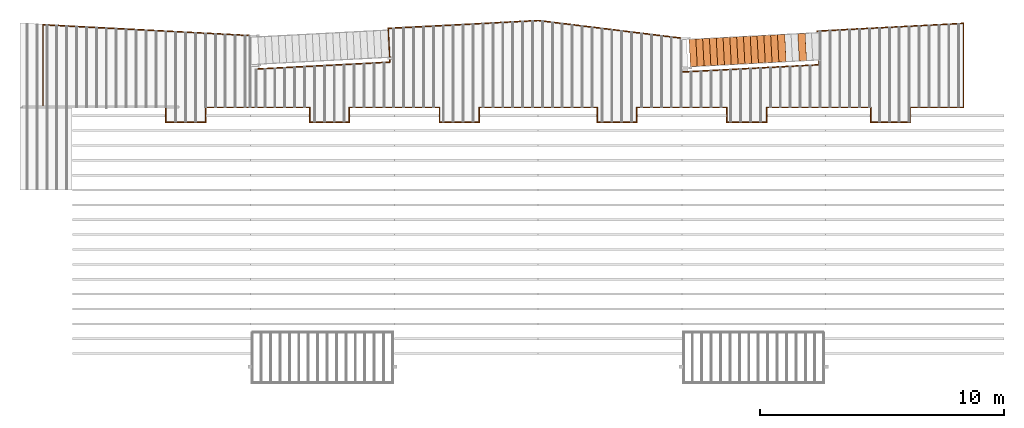
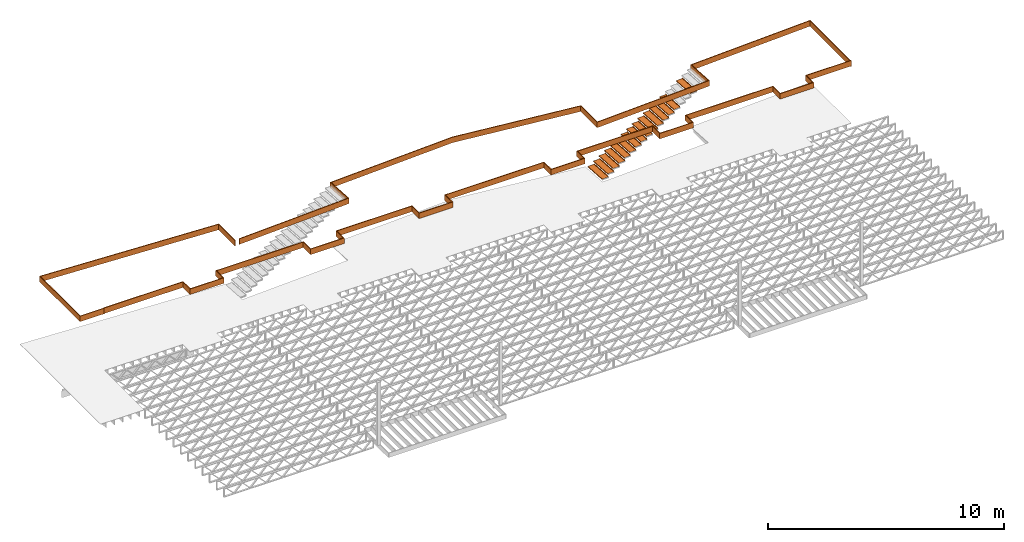
# One storey, part 15 of 23: 17 proxies.
"""IFC4 building model written with IfcOpenShell, lengths in feet."""

from ifc_helpers import new_model, entity, si_unit, converted_unit, derived_unit, direction, frame, origin, place, context, subcontext, project, spatial, polyline, outline, extrude, source, transform, mapped, material, type_object, type_shapes, element, save


model = new_model("IFC4")

# Units and contexts
model_context_1 = context("Model", 3, precision=0.0001, world=origin(), true_north=direction((6.12303176911189e-17, 1.0)))
model_context_2 = context("Model", 3, precision=0.0001, world=origin(), true_north=direction((6.12303176911189e-17, 1.0)))
body_context = subcontext(model_context_2, "Body", "Model", "MODEL_VIEW")
ifc_project = project(units=[converted_unit("LENGTHUNIT", "FOOT", entity("IfcRatioMeasure", 0.3048), si_unit("LENGTHUNIT", "METRE"), dimensions=[1, 0, 0, 0, 0, 0, 0]), converted_unit("AREAUNIT", "SQUARE FOOT", entity("IfcRatioMeasure", 0.09290304), si_unit("AREAUNIT", "SQUARE_METRE"), dimensions=[2, 0, 0, 0, 0, 0, 0]), converted_unit("VOLUMEUNIT", "CUBIC FOOT", entity("IfcRatioMeasure", 0.028316846592), si_unit("VOLUMEUNIT", "CUBIC_METRE"), dimensions=[3, 0, 0, 0, 0, 0, 0]), converted_unit("PLANEANGLEUNIT", "DEGREE", entity("IfcRatioMeasure", 0.0174532925199433), si_unit("PLANEANGLEUNIT", "RADIAN"), dimensions=[0, 0, 0, 0, 0, 0, 0]), si_unit("MASSUNIT", "GRAM", prefix="KILO"), derived_unit("MASSDENSITYUNIT", [(si_unit("MASSUNIT", "GRAM", prefix="KILO"), 1), (si_unit("LENGTHUNIT", "METRE"), -3)]), derived_unit("MOMENTOFINERTIAUNIT", [(si_unit("LENGTHUNIT", "METRE"), 4)]), si_unit("TIMEUNIT", "SECOND"), si_unit("FREQUENCYUNIT", "HERTZ"), si_unit("THERMODYNAMICTEMPERATUREUNIT", "DEGREE_CELSIUS"), derived_unit("THERMALTRANSMITTANCEUNIT", [(si_unit("MASSUNIT", "GRAM", prefix="KILO"), 1), (si_unit("THERMODYNAMICTEMPERATUREUNIT", "KELVIN"), -1), (si_unit("TIMEUNIT", "SECOND"), -3)]), derived_unit("VOLUMETRICFLOWRATEUNIT", [(si_unit("LENGTHUNIT", "METRE"), 3), (si_unit("TIMEUNIT", "SECOND"), -1)]), si_unit("ELECTRICCURRENTUNIT", "AMPERE"), si_unit("ELECTRICVOLTAGEUNIT", "VOLT"), si_unit("POWERUNIT", "WATT"), si_unit("FORCEUNIT", "NEWTON"), si_unit("ILLUMINANCEUNIT", "LUX"), si_unit("LUMINOUSFLUXUNIT", "LUMEN"), si_unit("LUMINOUSINTENSITYUNIT", "CANDELA"), derived_unit("USERDEFINED", [(si_unit("MASSUNIT", "GRAM", prefix="KILO"), -1), (si_unit("LENGTHUNIT", "METRE"), -2), (si_unit("TIMEUNIT", "SECOND"), 3), (si_unit("LUMINOUSFLUXUNIT", "LUMEN"), 1)]), derived_unit("LINEARVELOCITYUNIT", [(si_unit("LENGTHUNIT", "METRE"), 1), (si_unit("TIMEUNIT", "SECOND"), -1)]), si_unit("PRESSUREUNIT", "PASCAL"), derived_unit("USERDEFINED", [(si_unit("LENGTHUNIT", "METRE"), -2), (si_unit("MASSUNIT", "GRAM", prefix="KILO"), 1), (si_unit("TIMEUNIT", "SECOND"), -2)]), derived_unit("LINEARFORCEUNIT", [(si_unit("MASSUNIT", "GRAM", prefix="KILO"), 1), (si_unit("LENGTHUNIT", "METRE"), 1), (si_unit("TIMEUNIT", "SECOND"), -2), (si_unit("LENGTHUNIT", "METRE"), -1)]), derived_unit("PLANARFORCEUNIT", [(si_unit("MASSUNIT", "GRAM", prefix="KILO"), 1), (si_unit("LENGTHUNIT", "METRE"), 1), (si_unit("TIMEUNIT", "SECOND"), -2), (si_unit("LENGTHUNIT", "METRE"), -2)])], contexts=[model_context_1])

# Site, building, storey
site_placement = place(None, origin())
site = spatial("IfcSite", under=ifc_project, at=site_placement, CompositionType="ELEMENT")
building_placement = place(site_placement, origin())
building = spatial("IfcBuilding", under=site, at=building_placement, CompositionType="ELEMENT")
storey_placement = place(building_placement, frame((0.0, 0.0, 10.8020833333333)))
storey = spatial("IfcBuildingStorey", under=building, at=storey_placement, Name="2ND FLOOR", CompositionType="ELEMENT", Elevation=10.8020833333333)

# Proxies
ifc_material_1 = material(Name="BRAKE METAL FLASHING AT PERIMETER 2X LEDGER", Category="Materials")
building_element_proxy_type_1 = type_object("IfcBuildingElementProxyType", Name="Structural Framing 10:Structural Framing 10", PredefinedType="NOTDEFINED", material=ifc_material_1)
shared_shape_1 = source(origin(), body_context, "Body", "SweptSolid", [
    extrude(outline(polyline([(-7.56753895396921, -42.2774157655166), (3.87966828565245, -42.2774157655166), (2.84075976230344, -22.4538602254437), (-1.69469338261541, -22.6913475810637), (-2.65710623777287, -4.32741634172971), (1.89079299111185, -4.32741634172969), (4.2646279059843, 15.0059175678136), (3.20329361123053, 35.2573823173956), (-1.33214906717884, 35.0196898385549), (-2.2789485125582, 53.085699471748), (-2.4037772044025, 53.0791574772176), (-1.45043576449265, 34.8883191521804), (3.08500691391683, 35.1260116310211), (4.13922686378191, 15.0102966687023), (1.78020233304241, -4.20241634172977), (-2.7888287534328, -4.20241634172985), (-1.81298037577432, -22.8227126223806), (2.72247276914442, -22.5852252667607), (3.74794576999241, -42.1524157655166), (-7.56753895396921, -42.1524157655166), (-7.56753895396921, -42.2774157655166)])), frame((81.6716675678157, 7.56754075120455, 0.0), z_axis=(0.0, 0.0, 1.0), x_axis=(0.0, 1.0, 0.0)), (0.0, 0.0, 1.0), 0.9375),
    extrude(outline(polyline([(8.04599253803074, -5.11661078283554), (8.04599253803075, -5.24161078283554), (11.9880614770721, -5.24161078283542), (11.9880614770717, 6.03149352153641), (-16.0110697093404, 4.56412123420146), (-16.0110218563282, -0.108947414546855), (-15.8860697093402, -0.115495879087139), (-15.8860697093407, 4.44550066336238), (11.8630614770719, 5.89977100587647), (11.8630614770721, -5.11661078283554), (8.04599253803074, -5.11661078283554)])), frame((11.9880614770724, 5.24161078283623, 0.0), z_axis=(0.0, 0.0, -1.0), x_axis=(-1.0, 0.0, 0.0)), (0.0, 0.0, -1.0), 0.9375),
])
type_shapes(building_element_proxy_type_1, [shared_shape_1])
proxy_1_placement = place(storey_placement, frame((-269.737243818863, 958.903601069585, 9.4687500000001)))
element("IfcBuildingElementProxy", 1, at=proxy_1_placement, inside=storey, type_object=building_element_proxy_type_1, material=ifc_material_1, Name="Structural Framing 10:Structural Framing 10", ObjectType="Structural Framing 10:Structural Framing 10", PredefinedType="NOTDEFINED", context=body_context, shape_type="MappedRepresentation", body=[
    mapped(shared_shape_1, transform((0.0, 0.0, 0.0), scale=1.0)),
])
ifc_material_2 = material(Name="TREATED 2X LEDGER - EXT. STAIN", Category="Materials")
building_element_proxy_type_2 = type_object("IfcBuildingElementProxyType", Name="Structural Framing 30:Structural Framing 10", PredefinedType="NOTDEFINED", material=ifc_material_2)
shared_shape_2 = source(origin(), body_context, "Body", "SweptSolid", [
    extrude(outline(polyline([(-62.5882752409424, -0.860575797798219), (-62.5882752409424, -0.985575797798219), (-49.7925957869951, -0.985575797798219), (-49.7925952844915, 1.01442372247004), (-44.5790513990362, 1.01442372246993), (-44.5790508965316, -0.985580263202678), (-30.4592588644664, -0.985576715578077), (-30.4592593669705, 1.01442372247004), (-25.245716639162, 1.01442372247004), (-25.2457166391621, -0.985579727022696), (-12.9957192201912, -0.98557673237417), (-12.9957197091137, 1.01442372246993), (-7.78738545573532, 1.01442372246981), (-7.78738595421945, -0.985575581580974), (8.21261399126007, -0.985579569456718), (8.21261399126004, 1.01442372247004), (13.4209478126482, 1.01442372247004), (13.4209478126482, -0.985579727024628), (25.6709474765803, -0.985576732373261), (25.6709469876575, 1.01442372246993), (30.8844877145134, 1.01442372247004), (30.884487212011, -0.985575550993076), (45.0042807971791, -0.985579098609605), (45.0042807971789, 1.01442372247027), (50.2126139732988, 1.01442372247038), (50.2126144758024, -0.985575765082217), (57.4959474606437, -0.985577595032396), (57.4959474920499, -0.860577595032169), (50.3376144443961, -0.860575796488433), (50.3376139418926, 1.13942372247061), (44.8792807971786, 1.13942372247061), (44.8792807971788, -0.860579067202821), (31.0094872434177, -0.860575582399179), (31.0094877459201, 1.13942372247027), (25.5459469570995, 1.13942372247027), (25.5459474460225, -0.860576762930805), (13.5459478126485, -0.860579696466743), (13.5459478126485, 1.13942372247038), (8.08761399125981, 1.13942372247027), (8.08761399125981, -0.860579538301181), (-7.66238592306419, -0.860575612736284), (-7.66238542457992, 1.13942372246993), (-13.1207197396713, 1.13942372246981), (-13.1207192507489, -0.860576762931714), (-25.1207166391621, -0.860579696465038), (-25.1207166391621, 1.13942372246993), (-30.584259398377, 1.13942372247004), (-30.584258895873, -0.860576746984407), (-44.4540509279381, -0.860580231796234), (-44.4540514304427, 1.13942372246993), (-49.9175952530849, 1.13942372246993), (-49.9175957555886, -0.860575797798219), (-62.5882752409424, -0.860575797798219)])), frame((62.5882752409424, 1.13942372247061, 0.0), z_axis=(0.0, 0.0, -1.0), x_axis=(1.0, 0.0, 0.0)), (0.0, 0.0, -1.0), 0.9375),
])
type_shapes(building_element_proxy_type_2, [shared_shape_2])
proxy_2_placement = place(storey_placement, frame((-265.872383218523, 956.903601549317, 9.52083333333334)))
element("IfcBuildingElementProxy", 2, at=proxy_2_placement, inside=storey, type_object=building_element_proxy_type_2, material=ifc_material_2, Name="Structural Framing 30:Structural Framing 10", ObjectType="Structural Framing 30:Structural Framing 10", PredefinedType="NOTDEFINED", context=body_context, shape_type="MappedRepresentation", body=[
    mapped(shared_shape_2, transform((0.0, 0.0, 0.0), scale=1.0)),
])
ifc_material_3 = material(Name="GALV. STEEL TREAD", Category="Materials")
building_element_proxy_type_3 = type_object("IfcBuildingElementProxyType", Name="Generic Models 802:Generic Models 629", PredefinedType="NOTDEFINED", material=ifc_material_3)
shared_shape_3 = source(origin(), body_context, "Body", "SweptSolid", [
    extrude(outline(polyline([(-0.597916666666581, 0.02708333333333), (-0.597916666666569, -0.118750000000006), (-0.587499999999929, -0.118750000000006), (-0.587499999999947, 0.0166666666666657), (0.391666666666667, 0.0166666666666657), (0.391666666666679, -0.118750000000006), (0.402083333333376, -0.118750000000006), (0.402083333333369, 0.193750000000001), (0.391666666666649, 0.193750000000001), (0.391666666666667, 0.02708333333333), (-0.597916666666581, 0.02708333333333)])), frame((0.791176413725168, 0.0312925405037277, 0.118750000000009), z_axis=(0.0523359562429694, -0.998629534754573, 0.0), x_axis=(0.998629534754573, 0.0523359562429694, 0.0)), (0.0, 0.0, -1.0), 3.70833333337879),
])
type_shapes(building_element_proxy_type_3, [shared_shape_3])
proxy_3_placement = place(storey_placement, frame((-171.796644235969, 965.013307028824, 6.41392543859246)))
element("IfcBuildingElementProxy", 3, at=proxy_3_placement, inside=storey, type_object=building_element_proxy_type_3, material=ifc_material_3, Name="Generic Models 802:Generic Models 629", ObjectType="Generic Models 802:Generic Models 629", PredefinedType="NOTDEFINED", context=body_context, shape_type="MappedRepresentation", body=[
    mapped(shared_shape_3, transform((0.0, 0.0, 0.0), scale=1.0)),
])
building_element_proxy_type_4 = type_object("IfcBuildingElementProxyType", Name="Generic Models 808:Generic Models 629", PredefinedType="NOTDEFINED", material=ifc_material_3)
shared_shape_4 = source(origin(), body_context, "Body", "SweptSolid", [
    extrude(outline(polyline([(-0.597916666666581, 0.02708333333333), (-0.597916666666569, -0.118750000000006), (-0.587499999999929, -0.118750000000006), (-0.587499999999947, 0.0166666666666657), (0.391666666666667, 0.0166666666666657), (0.391666666666679, -0.118750000000006), (0.402083333333376, -0.118750000000006), (0.402083333333369, 0.193750000000001), (0.391666666666649, 0.193750000000001), (0.391666666666667, 0.02708333333333), (-0.597916666666581, 0.02708333333333)])), frame((0.791176413725168, 0.031292540503614, 0.118750000000006), z_axis=(0.0523359562429694, -0.998629534754573, 0.0), x_axis=(0.998629534754573, 0.0523359562429694, 0.0)), (0.0, 0.0, -1.0), 3.70833333337879),
])
type_shapes(building_element_proxy_type_4, [shared_shape_4])
proxy_4_placement = place(storey_placement, frame((-168.137157266468, 965.205092614211, 8.6595394736803)))
element("IfcBuildingElementProxy", 4, at=proxy_4_placement, inside=storey, type_object=building_element_proxy_type_4, material=ifc_material_3, Name="Generic Models 808:Generic Models 629", ObjectType="Generic Models 808:Generic Models 629", PredefinedType="NOTDEFINED", context=body_context, shape_type="MappedRepresentation", body=[
    mapped(shared_shape_4, transform((0.0, 0.0, 0.0), scale=1.0)),
])
building_element_proxy_type_5 = type_object("IfcBuildingElementProxyType", Name="Generic Models 814:Generic Models 629", PredefinedType="NOTDEFINED", material=ifc_material_3)
shared_shape_5 = source(origin(), body_context, "Body", "SweptSolid", [
    extrude(outline(polyline([(-0.597916666666581, 0.0270833333333336), (-0.597916666666569, -0.118750000000002), (-0.587499999999929, -0.118750000000002), (-0.587499999999947, 0.0166666666666693), (0.391666666666667, 0.0166666666666693), (0.391666666666679, -0.118750000000002), (0.402083333333376, -0.118750000000002), (0.402083333333369, 0.193750000000005), (0.391666666666649, 0.193750000000005), (0.391666666666667, 0.0270833333333336), (-0.597916666666581, 0.0270833333333336)])), frame((0.791176413725168, 0.0312925405037277, 0.118750000000002), z_axis=(0.0523359562429694, -0.998629534754573, 0.0), x_axis=(0.998629534754573, 0.0523359562429694, 0.0)), (0.0, 0.0, -1.0), 3.70833333337879),
])
type_shapes(building_element_proxy_type_5, [shared_shape_5])
proxy_5_placement = place(storey_placement, frame((-170.881772493594, 965.06125342517, 6.97532894736442)))
element("IfcBuildingElementProxy", 5, at=proxy_5_placement, inside=storey, type_object=building_element_proxy_type_5, material=ifc_material_3, Name="Generic Models 814:Generic Models 629", ObjectType="Generic Models 814:Generic Models 629", PredefinedType="NOTDEFINED", context=body_context, shape_type="MappedRepresentation", body=[
    mapped(shared_shape_5, transform((0.0, 0.0, 0.0), scale=1.0)),
])
building_element_proxy_type_6 = type_object("IfcBuildingElementProxyType", Name="Generic Models 816:Generic Models 629", PredefinedType="NOTDEFINED", material=ifc_material_3)
shared_shape_6 = source(origin(), body_context, "Body", "SweptSolid", [
    extrude(outline(polyline([(-0.597916666666609, 0.0270833333333336), (-0.597916666666598, -0.118750000000002), (-0.587499999999957, -0.118750000000002), (-0.587499999999975, 0.0166666666666693), (0.391666666666639, 0.0166666666666693), (0.39166666666665, -0.118750000000002), (0.402083333333348, -0.118750000000002), (0.40208333333334, 0.193750000000005), (0.391666666666621, 0.193750000000005), (0.391666666666639, 0.0270833333333336), (-0.597916666666609, 0.0270833333333336)])), frame((0.791176413725196, 0.0312925405037277, 0.118750000000002), z_axis=(0.0523359562429694, -0.998629534754573, 0.0), x_axis=(0.998629534754573, 0.0523359562429694, 0.0)), (0.0, 0.0, -1.0), 3.70833333337879),
])
type_shapes(building_element_proxy_type_6, [shared_shape_6])
proxy_6_placement = place(storey_placement, frame((-172.711515978344, 964.965360632477, 5.85252192982051)))
element("IfcBuildingElementProxy", 6, at=proxy_6_placement, inside=storey, type_object=building_element_proxy_type_6, material=ifc_material_3, Name="Generic Models 816:Generic Models 629", ObjectType="Generic Models 816:Generic Models 629", PredefinedType="NOTDEFINED", context=body_context, shape_type="MappedRepresentation", body=[
    mapped(shared_shape_6, transform((0.0, 0.0, 0.0), scale=1.0)),
])
building_element_proxy_type_7 = type_object("IfcBuildingElementProxyType", Name="Generic Models 818:Generic Models 629", PredefinedType="NOTDEFINED", material=ifc_material_3)
shared_shape_7 = source(origin(), body_context, "Body", "SweptSolid", [
    extrude(outline(polyline([(-0.597916666666581, 0.0270833333333336), (-0.597916666666569, -0.118750000000002), (-0.587499999999929, -0.118750000000002), (-0.587499999999947, 0.0166666666666693), (0.391666666666667, 0.0166666666666693), (0.391666666666679, -0.118750000000002), (0.402083333333376, -0.118750000000002), (0.402083333333369, 0.193750000000005), (0.391666666666649, 0.193750000000005), (0.391666666666667, 0.0270833333333336), (-0.597916666666581, 0.0270833333333336)])), frame((0.791176413725168, 0.0312925405037277, 0.118750000000006), z_axis=(0.0523359562429694, -0.998629534754573, 0.0), x_axis=(0.998629534754573, 0.0523359562429694, 0.0)), (0.0, 0.0, -1.0), 3.70833333337879),
])
type_shapes(building_element_proxy_type_7, [shared_shape_7])
proxy_7_placement = place(storey_placement, frame((-173.626387720719, 964.917414236131, 5.29111842104855)))
element("IfcBuildingElementProxy", 7, at=proxy_7_placement, inside=storey, type_object=building_element_proxy_type_7, material=ifc_material_3, Name="Generic Models 818:Generic Models 629", ObjectType="Generic Models 818:Generic Models 629", PredefinedType="NOTDEFINED", context=body_context, shape_type="MappedRepresentation", body=[
    mapped(shared_shape_7, transform((0.0, 0.0, 0.0), scale=1.0)),
])
building_element_proxy_type_8 = type_object("IfcBuildingElementProxyType", Name="Generic Models 820:Generic Models 629", PredefinedType="NOTDEFINED", material=ifc_material_3)
shared_shape_8 = source(origin(), body_context, "Body", "SweptSolid", [
    extrude(outline(polyline([(-0.597916666666609, 0.02708333333333), (-0.597916666666598, -0.118750000000006), (-0.587499999999985, -0.118750000000006), (-0.587499999999975, 0.0166666666666657), (0.391666666666639, 0.0166666666666657), (0.39166666666665, -0.118750000000006), (0.402083333333319, -0.118750000000006), (0.40208333333334, 0.193750000000001), (0.391666666666621, 0.193750000000001), (0.391666666666639, 0.02708333333333), (-0.597916666666609, 0.02708333333333)])), frame((0.791176413725196, 0.031292540503955, 0.118750000000004), z_axis=(0.0523359562429694, -0.998629534754573, 0.0), x_axis=(0.998629534754573, 0.0523359562429694, 0.0)), (0.0, 0.0, -1.0), 3.70833333337879),
])
type_shapes(building_element_proxy_type_8, [shared_shape_8])
proxy_8_placement = place(storey_placement, frame((-174.541259463095, 964.869467839784, 4.7297149122766)))
element("IfcBuildingElementProxy", 8, at=proxy_8_placement, inside=storey, type_object=building_element_proxy_type_8, material=ifc_material_3, Name="Generic Models 820:Generic Models 629", ObjectType="Generic Models 820:Generic Models 629", PredefinedType="NOTDEFINED", context=body_context, shape_type="MappedRepresentation", body=[
    mapped(shared_shape_8, transform((0.0, 0.0, 0.0), scale=1.0)),
])
building_element_proxy_type_9 = type_object("IfcBuildingElementProxyType", Name="Generic Models 822:Generic Models 629", PredefinedType="NOTDEFINED", material=ifc_material_3)
shared_shape_9 = source(origin(), body_context, "Body", "SweptSolid", [
    extrude(outline(polyline([(-0.597916666666581, 0.0270833333333336), (-0.597916666666569, -0.118750000000002), (-0.587499999999929, -0.118750000000002), (-0.587499999999947, 0.0166666666666693), (0.391666666666667, 0.0166666666666693), (0.391666666666679, -0.118750000000002), (0.402083333333376, -0.118750000000002), (0.402083333333369, 0.193750000000005), (0.391666666666649, 0.193750000000005), (0.391666666666667, 0.0270833333333336), (-0.597916666666581, 0.0270833333333336)])), frame((0.791176413725168, 0.031292540503614, 0.11875), z_axis=(0.0523359562429694, -0.998629534754573, 0.0), x_axis=(0.998629534754573, 0.0523359562429694, 0.0)), (0.0, 0.0, -1.0), 3.70833333337879),
])
type_shapes(building_element_proxy_type_9, [shared_shape_9])
proxy_9_placement = place(storey_placement, frame((-175.45613120547, 964.821521443437, 4.16831140350465)))
element("IfcBuildingElementProxy", 9, at=proxy_9_placement, inside=storey, type_object=building_element_proxy_type_9, material=ifc_material_3, Name="Generic Models 822:Generic Models 629", ObjectType="Generic Models 822:Generic Models 629", PredefinedType="NOTDEFINED", context=body_context, shape_type="MappedRepresentation", body=[
    mapped(shared_shape_9, transform((0.0, 0.0, 0.0), scale=1.0)),
])
building_element_proxy_type_10 = type_object("IfcBuildingElementProxyType", Name="Generic Models 824:Generic Models 629", PredefinedType="NOTDEFINED", material=ifc_material_3)
shared_shape_10 = source(origin(), body_context, "Body", "SweptSolid", [
    extrude(outline(polyline([(-0.597916666666609, 0.0270833333333318), (-0.597916666666598, -0.118750000000004), (-0.587499999999957, -0.118750000000004), (-0.587499999999975, 0.0166666666666675), (0.391666666666639, 0.0166666666666675), (0.39166666666665, -0.118750000000004), (0.402083333333348, -0.118750000000004), (0.40208333333334, 0.193750000000003), (0.391666666666621, 0.193750000000003), (0.391666666666639, 0.0270833333333318), (-0.597916666666609, 0.0270833333333318)])), frame((0.791176413725196, 0.0312925405038413, 0.118750000000002), z_axis=(0.0523359562429694, -0.998629534754573, 0.0), x_axis=(0.998629534754573, 0.0523359562429694, 0.0)), (0.0, 0.0, -1.0), 3.70833333337879),
])
type_shapes(building_element_proxy_type_10, [shared_shape_10])
proxy_10_placement = place(storey_placement, frame((-176.371002947845, 964.77357504709, 3.60690789473269)))
element("IfcBuildingElementProxy", 10, at=proxy_10_placement, inside=storey, type_object=building_element_proxy_type_10, material=ifc_material_3, Name="Generic Models 824:Generic Models 629", ObjectType="Generic Models 824:Generic Models 629", PredefinedType="NOTDEFINED", context=body_context, shape_type="MappedRepresentation", body=[
    mapped(shared_shape_10, transform((0.0, 0.0, 0.0), scale=1.0)),
])
building_element_proxy_type_11 = type_object("IfcBuildingElementProxyType", Name="Generic Models 826:Generic Models 629", PredefinedType="NOTDEFINED", material=ifc_material_3)
shared_shape_11 = source(origin(), body_context, "Body", "SweptSolid", [
    extrude(outline(polyline([(-0.597916666666581, 0.0270833333333353), (-0.597916666666569, -0.11875), (-0.587499999999929, -0.11875), (-0.587499999999947, 0.016666666666671), (0.391666666666667, 0.016666666666671), (0.391666666666679, -0.11875), (0.402083333333376, -0.11875), (0.402083333333369, 0.193750000000007), (0.391666666666649, 0.193750000000007), (0.391666666666667, 0.0270833333333353), (-0.597916666666581, 0.0270833333333353)])), frame((0.791176413725168, 0.031292540503614, 0.118749999999999), z_axis=(0.0523359562429694, -0.998629534754573, 0.0), x_axis=(0.998629534754573, 0.0523359562429694, 0.0)), (0.0, 0.0, -1.0), 3.70833333337879),
])
type_shapes(building_element_proxy_type_11, [shared_shape_11])
proxy_11_placement = place(storey_placement, frame((-177.28587469022, 964.725628650744, 3.04550438596073)))
element("IfcBuildingElementProxy", 11, at=proxy_11_placement, inside=storey, type_object=building_element_proxy_type_11, material=ifc_material_3, Name="Generic Models 826:Generic Models 629", ObjectType="Generic Models 826:Generic Models 629", PredefinedType="NOTDEFINED", context=body_context, shape_type="MappedRepresentation", body=[
    mapped(shared_shape_11, transform((0.0, 0.0, 0.0), scale=1.0)),
])
building_element_proxy_type_12 = type_object("IfcBuildingElementProxyType", Name="Generic Models 828:Generic Models 629", PredefinedType="NOTDEFINED", material=ifc_material_3)
shared_shape_12 = source(origin(), body_context, "Body", "SweptSolid", [
    extrude(outline(polyline([(-0.597916666666609, 0.02708333333333), (-0.597916666666598, -0.118750000000006), (-0.587499999999957, -0.118750000000006), (-0.587499999999975, 0.0166666666666657), (0.391666666666639, 0.0166666666666657), (0.39166666666665, -0.118750000000006), (0.402083333333348, -0.118750000000006), (0.40208333333334, 0.193750000000001), (0.391666666666621, 0.193750000000001), (0.391666666666639, 0.02708333333333), (-0.597916666666609, 0.02708333333333)])), frame((0.791176413725196, 0.0312925405038413, 0.118750000000004), z_axis=(0.0523359562429694, -0.998629534754573, 0.0), x_axis=(0.998629534754573, 0.0523359562429694, 0.0)), (0.0, 0.0, -1.0), 3.70833333337879),
])
type_shapes(building_element_proxy_type_12, [shared_shape_12])
proxy_12_placement = place(storey_placement, frame((-178.200746432596, 964.677682254397, 2.48410087718878)))
element("IfcBuildingElementProxy", 12, at=proxy_12_placement, inside=storey, type_object=building_element_proxy_type_12, material=ifc_material_3, Name="Generic Models 828:Generic Models 629", ObjectType="Generic Models 828:Generic Models 629", PredefinedType="NOTDEFINED", context=body_context, shape_type="MappedRepresentation", body=[
    mapped(shared_shape_12, transform((0.0, 0.0, 0.0), scale=1.0)),
])
building_element_proxy_type_13 = type_object("IfcBuildingElementProxyType", Name="Generic Models 830:Generic Models 629", PredefinedType="NOTDEFINED", material=ifc_material_3)
shared_shape_13 = source(origin(), body_context, "Body", "SweptSolid", [
    extrude(outline(polyline([(-0.597916666666581, 0.0270833333333336), (-0.597916666666569, -0.118750000000002), (-0.587499999999929, -0.118750000000002), (-0.587499999999947, 0.0166666666666693), (0.391666666666667, 0.0166666666666693), (0.391666666666679, -0.118750000000002), (0.402083333333376, -0.118750000000002), (0.402083333333369, 0.193750000000005), (0.391666666666649, 0.193750000000005), (0.391666666666667, 0.0270833333333336), (-0.597916666666581, 0.0270833333333336)])), frame((0.791176413725168, 0.0312925405037277, 0.11875), z_axis=(0.0523359562429694, -0.998629534754573, 0.0), x_axis=(0.998629534754573, 0.0523359562429694, 0.0)), (0.0, 0.0, -1.0), 3.70833333337879),
])
type_shapes(building_element_proxy_type_13, [shared_shape_13])
proxy_13_placement = place(storey_placement, frame((-179.115618174971, 964.62973585805, 1.92269736841682)))
element("IfcBuildingElementProxy", 13, at=proxy_13_placement, inside=storey, type_object=building_element_proxy_type_13, material=ifc_material_3, Name="Generic Models 830:Generic Models 629", ObjectType="Generic Models 830:Generic Models 629", PredefinedType="NOTDEFINED", context=body_context, shape_type="MappedRepresentation", body=[
    mapped(shared_shape_13, transform((0.0, 0.0, 0.0), scale=1.0)),
])
building_element_proxy_type_14 = type_object("IfcBuildingElementProxyType", Name="Generic Models 832:Generic Models 629", PredefinedType="NOTDEFINED", material=ifc_material_3)
shared_shape_14 = source(origin(), body_context, "Body", "SweptSolid", [
    extrude(outline(polyline([(-0.597916666666609, 0.0270833333333318), (-0.597916666666598, -0.118750000000004), (-0.587499999999985, -0.118750000000004), (-0.587499999999975, 0.0166666666666675), (0.391666666666639, 0.0166666666666675), (0.39166666666665, -0.118750000000004), (0.402083333333319, -0.118750000000004), (0.40208333333334, 0.193750000000003), (0.391666666666621, 0.193750000000003), (0.391666666666639, 0.0270833333333318), (-0.597916666666609, 0.0270833333333318)])), frame((0.791176413725196, 0.031292540503955, 0.118750000000002), z_axis=(0.0523359562429694, -0.998629534754573, 0.0), x_axis=(0.998629534754573, 0.0523359562429694, 0.0)), (0.0, 0.0, -1.0), 3.70833333337879),
])
type_shapes(building_element_proxy_type_14, [shared_shape_14])
proxy_14_placement = place(storey_placement, frame((-180.030489917346, 964.581789461704, 1.36129385964486)))
element("IfcBuildingElementProxy", 14, at=proxy_14_placement, inside=storey, type_object=building_element_proxy_type_14, material=ifc_material_3, Name="Generic Models 832:Generic Models 629", ObjectType="Generic Models 832:Generic Models 629", PredefinedType="NOTDEFINED", context=body_context, shape_type="MappedRepresentation", body=[
    mapped(shared_shape_14, transform((0.0, 0.0, 0.0), scale=1.0)),
])
building_element_proxy_type_15 = type_object("IfcBuildingElementProxyType", Name="Generic Models 834:Generic Models 629", PredefinedType="NOTDEFINED", material=ifc_material_3)
shared_shape_15 = source(origin(), body_context, "Body", "SweptSolid", [
    extrude(outline(polyline([(-0.597916666666581, 0.0270833333333353), (-0.597916666666569, -0.11875), (-0.587499999999929, -0.11875), (-0.587499999999947, 0.016666666666671), (0.391666666666667, 0.016666666666671), (0.391666666666679, -0.11875), (0.402083333333376, -0.11875), (0.402083333333369, 0.193750000000007), (0.391666666666649, 0.193750000000007), (0.391666666666667, 0.0270833333333353), (-0.597916666666581, 0.0270833333333353)])), frame((0.791176413725168, 0.0312925405037277, 0.118749999999999), z_axis=(0.0523359562429694, -0.998629534754573, 0.0), x_axis=(0.998629534754573, 0.0523359562429694, 0.0)), (0.0, 0.0, -1.0), 3.70833333337879),
])
type_shapes(building_element_proxy_type_15, [shared_shape_15])
proxy_15_placement = place(storey_placement, frame((-180.945361659721, 964.533843065357, 0.799890350872907)))
element("IfcBuildingElementProxy", 15, at=proxy_15_placement, inside=storey, type_object=building_element_proxy_type_15, material=ifc_material_3, Name="Generic Models 834:Generic Models 629", ObjectType="Generic Models 834:Generic Models 629", PredefinedType="NOTDEFINED", context=body_context, shape_type="MappedRepresentation", body=[
    mapped(shared_shape_15, transform((0.0, 0.0, 0.0), scale=1.0)),
])
building_element_proxy_type_16 = type_object("IfcBuildingElementProxyType", Name="Generic Models 836:Generic Models 629", PredefinedType="NOTDEFINED", material=ifc_material_3)
shared_shape_16 = source(origin(), body_context, "Body", "SweptSolid", [
    extrude(outline(polyline([(-0.597916666666609, 0.02708333333333), (-0.597916666666598, -0.118750000000006), (-0.587499999999957, -0.118750000000006), (-0.587499999999975, 0.0166666666666657), (0.391666666666639, 0.0166666666666657), (0.39166666666665, -0.118750000000006), (0.402083333333348, -0.118750000000006), (0.40208333333334, 0.193750000000001), (0.391666666666621, 0.193750000000001), (0.391666666666639, 0.02708333333333), (-0.597916666666609, 0.02708333333333)])), frame((0.791176413725196, 0.0312925405037277, 0.118750000000004), z_axis=(0.0523359562429694, -0.998629534754573, 0.0), x_axis=(0.998629534754573, 0.0523359562429694, 0.0)), (0.0, 0.0, -1.0), 3.70833333337879),
])
type_shapes(building_element_proxy_type_16, [shared_shape_16])
proxy_16_placement = place(storey_placement, frame((-181.860233402096, 964.48589666901, 0.238486842100951)))
element("IfcBuildingElementProxy", 16, at=proxy_16_placement, inside=storey, type_object=building_element_proxy_type_16, material=ifc_material_3, Name="Generic Models 836:Generic Models 629", ObjectType="Generic Models 836:Generic Models 629", PredefinedType="NOTDEFINED", context=body_context, shape_type="MappedRepresentation", body=[
    mapped(shared_shape_16, transform((0.0, 0.0, 0.0), scale=1.0)),
])
building_element_proxy_type_17 = type_object("IfcBuildingElementProxyType", Name="Generic Models 838:Generic Models 629", PredefinedType="NOTDEFINED", material=ifc_material_3)
shared_shape_17 = source(origin(), body_context, "Body", "SweptSolid", [
    extrude(outline(polyline([(-0.597916666666581, 0.0270833333333318), (-0.597916666666569, -0.118750000000004), (-0.587499999999929, -0.118750000000004), (-0.587499999999947, 0.0166666666666675), (0.391666666666667, 0.0166666666666675), (0.391666666666679, -0.118750000000004), (0.402083333333376, -0.118750000000004), (0.402083333333369, 0.193750000000003), (0.391666666666649, 0.193750000000003), (0.391666666666667, 0.0270833333333318), (-0.597916666666581, 0.0270833333333318)])), frame((0.791176413725168, 0.031292540503614, 0.118750000000002), z_axis=(0.0523359562429694, -0.998629534754573, 0.0), x_axis=(0.998629534754573, 0.0523359562429694, 0.0)), (0.0, 0.0, -1.0), 3.70833333337879),
])
type_shapes(building_element_proxy_type_17, [shared_shape_17])
proxy_17_placement = place(storey_placement, frame((-182.775105144472, 964.437950272664, -0.322916666671006)))
element("IfcBuildingElementProxy", 17, at=proxy_17_placement, inside=storey, type_object=building_element_proxy_type_17, material=ifc_material_3, Name="Generic Models 838:Generic Models 629", ObjectType="Generic Models 838:Generic Models 629", PredefinedType="NOTDEFINED", context=body_context, shape_type="MappedRepresentation", body=[
    mapped(shared_shape_17, transform((0.0, 0.0, 0.0), scale=1.0)),
])

save(model, "model.ifc")
